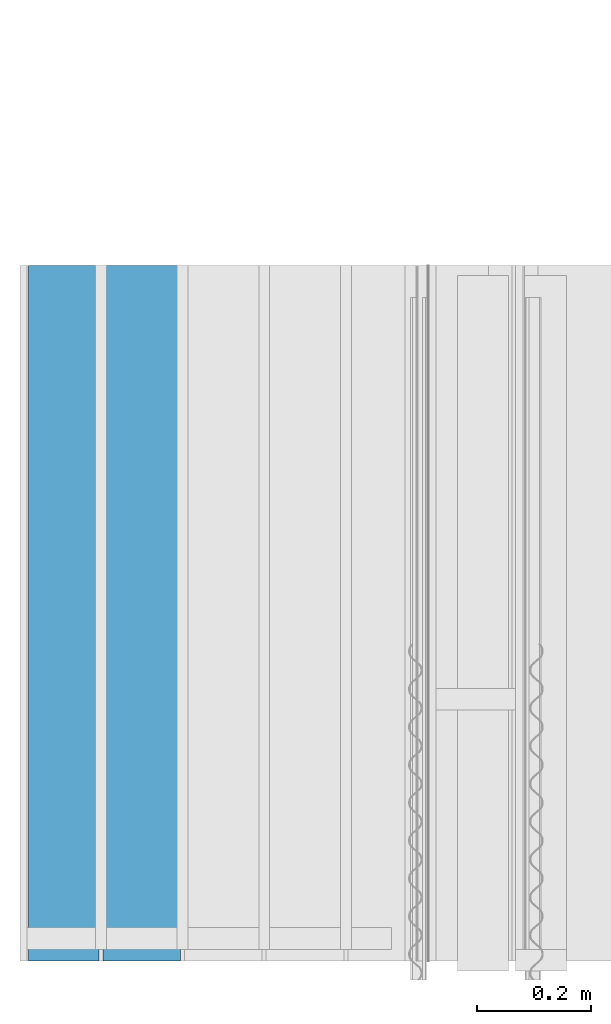
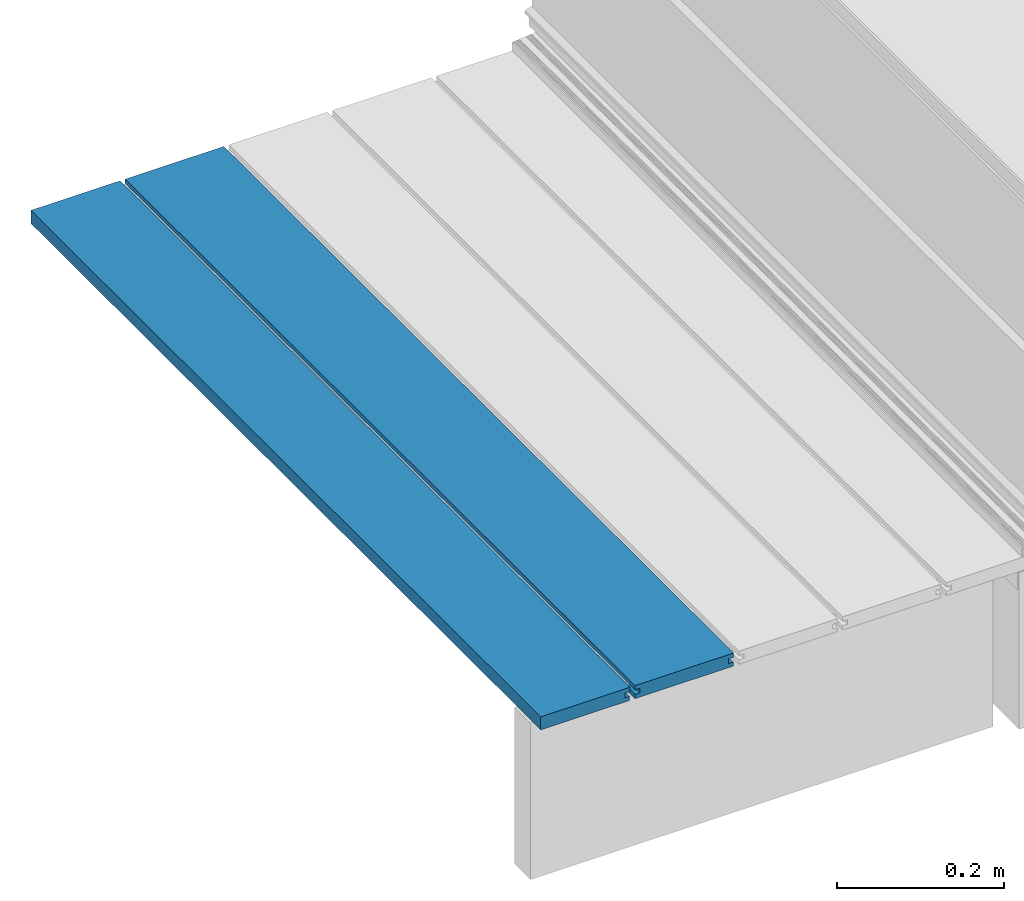
# One storey, part 7 of 33: 2 walls.
"""IFC4 building model written with IfcOpenShell, lengths in feet."""

from ifc_helpers import new_model, entity, si_unit, converted_unit, derived_unit, direction, frame, origin, place, context, subcontext, project, spatial, material, type_object, element, save


model = new_model("IFC4")

# Units and contexts
model_context = context("Model", 3, precision=0.0001, world=origin(), true_north=direction((6.12303176911189e-17, 1.0)))
body_context = subcontext(model_context, "Body", "Model", "MODEL_VIEW")
ifc_project = project(units=[converted_unit("LENGTHUNIT", "FOOT", entity("IfcRatioMeasure", 0.3048), si_unit("LENGTHUNIT", "METRE"), dimensions=[1, 0, 0, 0, 0, 0, 0]), converted_unit("AREAUNIT", "SQUARE FOOT", entity("IfcRatioMeasure", 0.09290304), si_unit("AREAUNIT", "SQUARE_METRE"), dimensions=[2, 0, 0, 0, 0, 0, 0]), converted_unit("VOLUMEUNIT", "CUBIC FOOT", entity("IfcRatioMeasure", 0.028316846592), si_unit("VOLUMEUNIT", "CUBIC_METRE"), dimensions=[3, 0, 0, 0, 0, 0, 0]), converted_unit("PLANEANGLEUNIT", "DEGREE", entity("IfcRatioMeasure", 0.0174532925199433), si_unit("PLANEANGLEUNIT", "RADIAN"), dimensions=[0, 0, 0, 0, 0, 0, 0]), si_unit("MASSUNIT", "GRAM", prefix="KILO"), derived_unit("MASSDENSITYUNIT", [(si_unit("MASSUNIT", "GRAM", prefix="KILO"), 1), (si_unit("LENGTHUNIT", "METRE"), -3)]), derived_unit("MOMENTOFINERTIAUNIT", [(si_unit("LENGTHUNIT", "METRE"), 4)]), si_unit("TIMEUNIT", "SECOND"), si_unit("FREQUENCYUNIT", "HERTZ"), si_unit("THERMODYNAMICTEMPERATUREUNIT", "DEGREE_CELSIUS"), derived_unit("THERMALTRANSMITTANCEUNIT", [(si_unit("MASSUNIT", "GRAM", prefix="KILO"), 1), (si_unit("THERMODYNAMICTEMPERATUREUNIT", "KELVIN"), -1), (si_unit("TIMEUNIT", "SECOND"), -3)]), derived_unit("VOLUMETRICFLOWRATEUNIT", [(si_unit("LENGTHUNIT", "METRE"), 3), (si_unit("TIMEUNIT", "SECOND"), -1)]), si_unit("ELECTRICCURRENTUNIT", "AMPERE"), si_unit("ELECTRICVOLTAGEUNIT", "VOLT"), si_unit("POWERUNIT", "WATT"), si_unit("FORCEUNIT", "NEWTON"), si_unit("ILLUMINANCEUNIT", "LUX"), si_unit("LUMINOUSFLUXUNIT", "LUMEN"), si_unit("LUMINOUSINTENSITYUNIT", "CANDELA"), derived_unit("USERDEFINED", [(si_unit("MASSUNIT", "GRAM", prefix="KILO"), -1), (si_unit("LENGTHUNIT", "METRE"), -2), (si_unit("TIMEUNIT", "SECOND"), 3), (si_unit("LUMINOUSFLUXUNIT", "LUMEN"), 1)]), derived_unit("LINEARVELOCITYUNIT", [(si_unit("LENGTHUNIT", "METRE"), 1), (si_unit("TIMEUNIT", "SECOND"), -1)]), si_unit("PRESSUREUNIT", "PASCAL"), derived_unit("USERDEFINED", [(si_unit("LENGTHUNIT", "METRE"), -2), (si_unit("MASSUNIT", "GRAM", prefix="KILO"), 1), (si_unit("TIMEUNIT", "SECOND"), -2)]), derived_unit("LINEARFORCEUNIT", [(si_unit("MASSUNIT", "GRAM", prefix="KILO"), 1), (si_unit("LENGTHUNIT", "METRE"), 1), (si_unit("TIMEUNIT", "SECOND"), -2), (si_unit("LENGTHUNIT", "METRE"), -1)]), derived_unit("PLANARFORCEUNIT", [(si_unit("MASSUNIT", "GRAM", prefix="KILO"), 1), (si_unit("LENGTHUNIT", "METRE"), 1), (si_unit("TIMEUNIT", "SECOND"), -2), (si_unit("LENGTHUNIT", "METRE"), -2)])], contexts=[model_context])

# Site, building, storey
site_placement = place(None, origin())
site = spatial("IfcSite", under=ifc_project, at=site_placement, CompositionType="ELEMENT")
building_placement = place(site_placement, origin())
building = spatial("IfcBuilding", under=site, at=building_placement, CompositionType="ELEMENT")
storey_placement = place(building_placement, frame((0.0, 0.0, 10.0)))
storey = spatial("IfcBuildingStorey", under=building, at=storey_placement, Name="2ND FLOOR", CompositionType="ELEMENT", Elevation=10.0000000000002)

# Walls
ifc_material = material(Name="COMPOSITE DECKING W/ HIDDEN FASTENERS", Category="Materials")
wall_type_1 = type_object("IfcWallType", Name="Generic Models 648:Generic Models 1", PredefinedType="NOTDEFINED", material=ifc_material)
wall_1_placement = place(storey_placement, frame((1457.39451875699, 2.0, 0.618921366607449), z_axis=(0.0, 0.0, 1.0), x_axis=(0.0, 1.0, 0.0)))
cartesian_point_1 = entity("IfcCartesianPoint", [4.0, 0.0, 0.0])
vertex_point_1 = entity("IfcVertexPoint", cartesian_point_1)
cartesian_point_2 = entity("IfcCartesianPoint", [4.0, 0.0, 0.0198779960861497])
vertex_point_2 = entity("IfcVertexPoint", cartesian_point_2)
ifc_direction_1 = entity("IfcDirection", [0.0, 0.0, 1.0])
edge_curve_1 = entity("IfcEdgeCurve", vertex_point_1, vertex_point_2, entity("IfcTrimmedCurve", entity("IfcLine", cartesian_point_1, entity("IfcVector", ifc_direction_1, 1.0)), [cartesian_point_1], [cartesian_point_2], True, "CARTESIAN"), True)
cartesian_point_3 = entity("IfcCartesianPoint", [4.0, -0.0228400010810219, 0.0198779960861497])
vertex_point_3 = entity("IfcVertexPoint", cartesian_point_3)
ifc_direction_2 = entity("IfcDirection", [0.0, -1.0, 0.0])
edge_curve_2 = entity("IfcEdgeCurve", vertex_point_2, vertex_point_3, entity("IfcTrimmedCurve", entity("IfcLine", cartesian_point_2, entity("IfcVector", ifc_direction_2, 1.0)), [cartesian_point_2], [cartesian_point_3], True, "CARTESIAN"), True)
cartesian_point_4 = entity("IfcCartesianPoint", [4.0, -0.0228400010810219, 0.0422987663426539])
vertex_point_4 = entity("IfcVertexPoint", cartesian_point_4)
edge_curve_3 = entity("IfcEdgeCurve", vertex_point_3, vertex_point_4, entity("IfcTrimmedCurve", entity("IfcLine", cartesian_point_3, entity("IfcVector", ifc_direction_1, 1.0)), [cartesian_point_3], [cartesian_point_4], True, "CARTESIAN"), True)
cartesian_point_5 = entity("IfcCartesianPoint", [4.0, 0.0, 0.0422987663426539])
vertex_point_5 = entity("IfcVertexPoint", cartesian_point_5)
ifc_direction_3 = entity("IfcDirection", [0.0, 1.0, 0.0])
edge_curve_4 = entity("IfcEdgeCurve", vertex_point_4, vertex_point_5, entity("IfcTrimmedCurve", entity("IfcLine", cartesian_point_4, entity("IfcVector", ifc_direction_3, 1.0)), [cartesian_point_4], [cartesian_point_5], True, "CARTESIAN"), True)
cartesian_point_6 = entity("IfcCartesianPoint", [4.0, 0.0, 0.0625000000000018])
vertex_point_6 = entity("IfcVertexPoint", cartesian_point_6)
edge_curve_5 = entity("IfcEdgeCurve", vertex_point_5, vertex_point_6, entity("IfcTrimmedCurve", entity("IfcLine", cartesian_point_5, entity("IfcVector", ifc_direction_1, 1.0)), [cartesian_point_5], [cartesian_point_6], True, "CARTESIAN"), True)
cartesian_point_7 = entity("IfcCartesianPoint", [4.0, -0.446740923891639, 0.0625000000000568])
vertex_point_7 = entity("IfcVertexPoint", cartesian_point_7)
edge_curve_6 = entity("IfcEdgeCurve", vertex_point_6, vertex_point_7, entity("IfcTrimmedCurve", entity("IfcLine", cartesian_point_6, entity("IfcVector", ifc_direction_2, 1.0)), [cartesian_point_6], [cartesian_point_7], True, "CARTESIAN"), True)
cartesian_point_8 = entity("IfcCartesianPoint", [4.0, -0.446740923891639, 0.0422987663426539])
vertex_point_8 = entity("IfcVertexPoint", cartesian_point_8)
ifc_direction_4 = entity("IfcDirection", [0.0, 0.0, -1.0])
edge_curve_7 = entity("IfcEdgeCurve", vertex_point_7, vertex_point_8, entity("IfcTrimmedCurve", entity("IfcLine", cartesian_point_7, entity("IfcVector", ifc_direction_4, 1.0)), [cartesian_point_7], [cartesian_point_8], True, "CARTESIAN"), True)
cartesian_point_9 = entity("IfcCartesianPoint", [4.0, -0.423900922810844, 0.0422987663426539])
vertex_point_9 = entity("IfcVertexPoint", cartesian_point_9)
edge_curve_8 = entity("IfcEdgeCurve", vertex_point_8, vertex_point_9, entity("IfcTrimmedCurve", entity("IfcLine", cartesian_point_8, entity("IfcVector", ifc_direction_3, 1.0)), [cartesian_point_8], [cartesian_point_9], True, "CARTESIAN"), True)
cartesian_point_10 = entity("IfcCartesianPoint", [4.0, -0.423900922810844, 0.0198779960861497])
vertex_point_10 = entity("IfcVertexPoint", cartesian_point_10)
edge_curve_9 = entity("IfcEdgeCurve", vertex_point_9, vertex_point_10, entity("IfcTrimmedCurve", entity("IfcLine", cartesian_point_9, entity("IfcVector", ifc_direction_4, 1.0)), [cartesian_point_9], [cartesian_point_10], True, "CARTESIAN"), True)
cartesian_point_11 = entity("IfcCartesianPoint", [4.0, -0.445416170097133, 0.0198779960861497])
vertex_point_11 = entity("IfcVertexPoint", cartesian_point_11)
edge_curve_10 = entity("IfcEdgeCurve", vertex_point_10, vertex_point_11, entity("IfcTrimmedCurve", entity("IfcLine", cartesian_point_10, entity("IfcVector", ifc_direction_2, 1.0)), [cartesian_point_10], [cartesian_point_11], True, "CARTESIAN"), True)
cartesian_point_12 = entity("IfcCartesianPoint", [4.0, -0.445416170097133, 0.0])
vertex_point_12 = entity("IfcVertexPoint", cartesian_point_12)
edge_curve_11 = entity("IfcEdgeCurve", vertex_point_11, vertex_point_12, entity("IfcTrimmedCurve", entity("IfcLine", cartesian_point_11, entity("IfcVector", ifc_direction_4, 1.0)), [cartesian_point_11], [cartesian_point_12], True, "CARTESIAN"), True)
edge_curve_12 = entity("IfcEdgeCurve", vertex_point_12, vertex_point_1, entity("IfcTrimmedCurve", entity("IfcLine", cartesian_point_12, entity("IfcVector", ifc_direction_3, 1.0)), [cartesian_point_12], [cartesian_point_1], True, "CARTESIAN"), True)
ifc_direction_5 = entity("IfcDirection", [1.0, 0.0, 0.0])
cartesian_point_13 = entity("IfcCartesianPoint", [0.0, 0.0, 0.0])
vertex_point_13 = entity("IfcVertexPoint", cartesian_point_13)
cartesian_point_14 = entity("IfcCartesianPoint", [0.0, -0.445416170097133, 0.0])
vertex_point_14 = entity("IfcVertexPoint", cartesian_point_14)
edge_curve_13 = entity("IfcEdgeCurve", vertex_point_13, vertex_point_14, entity("IfcTrimmedCurve", entity("IfcLine", cartesian_point_13, entity("IfcVector", ifc_direction_2, 1.0)), [cartesian_point_13], [cartesian_point_14], True, "CARTESIAN"), True)
cartesian_point_15 = entity("IfcCartesianPoint", [0.0, -0.445416170097133, 0.0198779960861462])
vertex_point_15 = entity("IfcVertexPoint", cartesian_point_15)
edge_curve_14 = entity("IfcEdgeCurve", vertex_point_14, vertex_point_15, entity("IfcTrimmedCurve", entity("IfcLine", cartesian_point_14, entity("IfcVector", ifc_direction_1, 1.0)), [cartesian_point_14], [cartesian_point_15], True, "CARTESIAN"), True)
cartesian_point_16 = entity("IfcCartesianPoint", [0.0, -0.423900922810844, 0.0198779960861462])
vertex_point_16 = entity("IfcVertexPoint", cartesian_point_16)
edge_curve_15 = entity("IfcEdgeCurve", vertex_point_15, vertex_point_16, entity("IfcTrimmedCurve", entity("IfcLine", cartesian_point_15, entity("IfcVector", ifc_direction_3, 1.0)), [cartesian_point_15], [cartesian_point_16], True, "CARTESIAN"), True)
cartesian_point_17 = entity("IfcCartesianPoint", [0.0, -0.423900922810844, 0.0422987663426522])
vertex_point_17 = entity("IfcVertexPoint", cartesian_point_17)
edge_curve_16 = entity("IfcEdgeCurve", vertex_point_16, vertex_point_17, entity("IfcTrimmedCurve", entity("IfcLine", cartesian_point_16, entity("IfcVector", ifc_direction_1, 1.0)), [cartesian_point_16], [cartesian_point_17], True, "CARTESIAN"), True)
cartesian_point_18 = entity("IfcCartesianPoint", [0.0, -0.446740923891639, 0.0422987663426522])
vertex_point_18 = entity("IfcVertexPoint", cartesian_point_18)
edge_curve_17 = entity("IfcEdgeCurve", vertex_point_17, vertex_point_18, entity("IfcTrimmedCurve", entity("IfcLine", cartesian_point_17, entity("IfcVector", ifc_direction_2, 1.0)), [cartesian_point_17], [cartesian_point_18], True, "CARTESIAN"), True)
cartesian_point_19 = entity("IfcCartesianPoint", [0.0, -0.446740923891639, 0.0625000000000551])
vertex_point_19 = entity("IfcVertexPoint", cartesian_point_19)
edge_curve_18 = entity("IfcEdgeCurve", vertex_point_18, vertex_point_19, entity("IfcTrimmedCurve", entity("IfcLine", cartesian_point_18, entity("IfcVector", ifc_direction_1, 1.0)), [cartesian_point_18], [cartesian_point_19], True, "CARTESIAN"), True)
cartesian_point_20 = entity("IfcCartesianPoint", [0.0, 0.0, 0.0624999999999982])
vertex_point_20 = entity("IfcVertexPoint", cartesian_point_20)
edge_curve_19 = entity("IfcEdgeCurve", vertex_point_19, vertex_point_20, entity("IfcTrimmedCurve", entity("IfcLine", cartesian_point_19, entity("IfcVector", ifc_direction_3, 1.0)), [cartesian_point_19], [cartesian_point_20], True, "CARTESIAN"), True)
cartesian_point_21 = entity("IfcCartesianPoint", [0.0, 0.0, 0.0422987663426522])
vertex_point_21 = entity("IfcVertexPoint", cartesian_point_21)
edge_curve_20 = entity("IfcEdgeCurve", vertex_point_20, vertex_point_21, entity("IfcTrimmedCurve", entity("IfcLine", cartesian_point_20, entity("IfcVector", ifc_direction_4, 1.0)), [cartesian_point_20], [cartesian_point_21], True, "CARTESIAN"), True)
cartesian_point_22 = entity("IfcCartesianPoint", [0.0, -0.0228400010810219, 0.0422987663426522])
vertex_point_22 = entity("IfcVertexPoint", cartesian_point_22)
edge_curve_21 = entity("IfcEdgeCurve", vertex_point_21, vertex_point_22, entity("IfcTrimmedCurve", entity("IfcLine", cartesian_point_21, entity("IfcVector", ifc_direction_2, 1.0)), [cartesian_point_21], [cartesian_point_22], True, "CARTESIAN"), True)
cartesian_point_23 = entity("IfcCartesianPoint", [0.0, -0.0228400010810219, 0.0198779960861462])
vertex_point_23 = entity("IfcVertexPoint", cartesian_point_23)
edge_curve_22 = entity("IfcEdgeCurve", vertex_point_22, vertex_point_23, entity("IfcTrimmedCurve", entity("IfcLine", cartesian_point_22, entity("IfcVector", ifc_direction_4, 1.0)), [cartesian_point_22], [cartesian_point_23], True, "CARTESIAN"), True)
cartesian_point_24 = entity("IfcCartesianPoint", [0.0, 0.0, 0.0198779960861462])
vertex_point_24 = entity("IfcVertexPoint", cartesian_point_24)
edge_curve_23 = entity("IfcEdgeCurve", vertex_point_23, vertex_point_24, entity("IfcTrimmedCurve", entity("IfcLine", cartesian_point_23, entity("IfcVector", ifc_direction_3, 1.0)), [cartesian_point_23], [cartesian_point_24], True, "CARTESIAN"), True)
edge_curve_24 = entity("IfcEdgeCurve", vertex_point_24, vertex_point_13, entity("IfcTrimmedCurve", entity("IfcLine", cartesian_point_24, entity("IfcVector", ifc_direction_4, 1.0)), [cartesian_point_24], [cartesian_point_13], True, "CARTESIAN"), True)
ifc_direction_6 = entity("IfcDirection", [-1.0, 0.0, 0.0])
edge_curve_25 = entity("IfcEdgeCurve", vertex_point_24, vertex_point_2, entity("IfcTrimmedCurve", entity("IfcLine", cartesian_point_24, entity("IfcVector", ifc_direction_5, 1.0)), [cartesian_point_24], [cartesian_point_2], True, "CARTESIAN"), True)
edge_curve_26 = entity("IfcEdgeCurve", vertex_point_1, vertex_point_13, entity("IfcTrimmedCurve", entity("IfcLine", cartesian_point_13, entity("IfcVector", ifc_direction_6, 1.0)), [cartesian_point_1], [cartesian_point_13], True, "CARTESIAN"), True)
edge_curve_27 = entity("IfcEdgeCurve", vertex_point_19, vertex_point_7, entity("IfcTrimmedCurve", entity("IfcLine", cartesian_point_19, entity("IfcVector", ifc_direction_5, 1.0)), [cartesian_point_19], [cartesian_point_7], True, "CARTESIAN"), True)
edge_curve_28 = entity("IfcEdgeCurve", vertex_point_6, vertex_point_20, entity("IfcTrimmedCurve", entity("IfcLine", cartesian_point_20, entity("IfcVector", ifc_direction_6, 1.0)), [cartesian_point_6], [cartesian_point_20], True, "CARTESIAN"), True)
edge_curve_29 = entity("IfcEdgeCurve", vertex_point_18, vertex_point_8, entity("IfcTrimmedCurve", entity("IfcLine", cartesian_point_18, entity("IfcVector", ifc_direction_5, 1.0)), [cartesian_point_18], [cartesian_point_8], True, "CARTESIAN"), True)
edge_curve_30 = entity("IfcEdgeCurve", vertex_point_12, vertex_point_14, entity("IfcTrimmedCurve", entity("IfcLine", cartesian_point_14, entity("IfcVector", ifc_direction_6, 1.0)), [cartesian_point_12], [cartesian_point_14], True, "CARTESIAN"), True)
edge_curve_31 = entity("IfcEdgeCurve", vertex_point_5, vertex_point_21, entity("IfcTrimmedCurve", entity("IfcLine", cartesian_point_21, entity("IfcVector", ifc_direction_6, 1.0)), [cartesian_point_5], [cartesian_point_21], True, "CARTESIAN"), True)
edge_curve_32 = entity("IfcEdgeCurve", vertex_point_17, vertex_point_9, entity("IfcTrimmedCurve", entity("IfcLine", cartesian_point_17, entity("IfcVector", ifc_direction_5, 1.0)), [cartesian_point_17], [cartesian_point_9], True, "CARTESIAN"), True)
edge_curve_33 = entity("IfcEdgeCurve", vertex_point_16, vertex_point_10, entity("IfcTrimmedCurve", entity("IfcLine", cartesian_point_16, entity("IfcVector", ifc_direction_5, 1.0)), [cartesian_point_16], [cartesian_point_10], True, "CARTESIAN"), True)
edge_curve_34 = entity("IfcEdgeCurve", vertex_point_15, vertex_point_11, entity("IfcTrimmedCurve", entity("IfcLine", cartesian_point_15, entity("IfcVector", ifc_direction_5, 1.0)), [cartesian_point_15], [cartesian_point_11], True, "CARTESIAN"), True)
edge_curve_35 = entity("IfcEdgeCurve", vertex_point_23, vertex_point_3, entity("IfcTrimmedCurve", entity("IfcLine", cartesian_point_23, entity("IfcVector", ifc_direction_5, 1.0)), [cartesian_point_23], [cartesian_point_3], True, "CARTESIAN"), True)
edge_curve_36 = entity("IfcEdgeCurve", vertex_point_22, vertex_point_4, entity("IfcTrimmedCurve", entity("IfcLine", cartesian_point_22, entity("IfcVector", ifc_direction_5, 1.0)), [cartesian_point_22], [cartesian_point_4], True, "CARTESIAN"), True)
element("IfcWall", 1, at=wall_1_placement, inside=storey, type_object=wall_type_1, material=ifc_material, Name="Generic Models 648:Generic Models 1", ObjectType="Generic Models 648:Generic Models 1", PredefinedType="NOTDEFINED", context=body_context, shape_type="AdvancedBrep", body=[
    entity("IfcAdvancedBrep", entity("IfcClosedShell", [entity("IfcAdvancedFace", [entity("IfcFaceOuterBound", entity("IfcEdgeLoop", [entity("IfcOrientedEdge", None, None, edge_curve_1, True), entity("IfcOrientedEdge", None, None, edge_curve_2, True), entity("IfcOrientedEdge", None, None, edge_curve_3, True), entity("IfcOrientedEdge", None, None, edge_curve_4, True), entity("IfcOrientedEdge", None, None, edge_curve_5, True), entity("IfcOrientedEdge", None, None, edge_curve_6, True), entity("IfcOrientedEdge", None, None, edge_curve_7, True), entity("IfcOrientedEdge", None, None, edge_curve_8, True), entity("IfcOrientedEdge", None, None, edge_curve_9, True), entity("IfcOrientedEdge", None, None, edge_curve_10, True), entity("IfcOrientedEdge", None, None, edge_curve_11, True), entity("IfcOrientedEdge", None, None, edge_curve_12, True)]), True)], entity("IfcPlane", entity("IfcAxis2Placement3D", entity("IfcCartesianPoint", [4.0, 3.98642313864389, 0.0]), ifc_direction_5, ifc_direction_3)), True), entity("IfcAdvancedFace", [entity("IfcFaceOuterBound", entity("IfcEdgeLoop", [entity("IfcOrientedEdge", None, None, edge_curve_13, True), entity("IfcOrientedEdge", None, None, edge_curve_14, True), entity("IfcOrientedEdge", None, None, edge_curve_15, True), entity("IfcOrientedEdge", None, None, edge_curve_16, True), entity("IfcOrientedEdge", None, None, edge_curve_17, True), entity("IfcOrientedEdge", None, None, edge_curve_18, True), entity("IfcOrientedEdge", None, None, edge_curve_19, True), entity("IfcOrientedEdge", None, None, edge_curve_20, True), entity("IfcOrientedEdge", None, None, edge_curve_21, True), entity("IfcOrientedEdge", None, None, edge_curve_22, True), entity("IfcOrientedEdge", None, None, edge_curve_23, True), entity("IfcOrientedEdge", None, None, edge_curve_24, True)]), True)], entity("IfcPlane", entity("IfcAxis2Placement3D", entity("IfcCartesianPoint", [0.0, 3.98642313864389, 0.0]), ifc_direction_6, ifc_direction_2)), True), entity("IfcAdvancedFace", [entity("IfcFaceOuterBound", entity("IfcEdgeLoop", [entity("IfcOrientedEdge", None, None, edge_curve_24, False), entity("IfcOrientedEdge", None, None, edge_curve_25, True), entity("IfcOrientedEdge", None, None, edge_curve_1, False), entity("IfcOrientedEdge", None, None, edge_curve_26, True)]), True)], entity("IfcPlane", entity("IfcAxis2Placement3D", cartesian_point_24, ifc_direction_3, ifc_direction_5)), True), entity("IfcAdvancedFace", [entity("IfcFaceOuterBound", entity("IfcEdgeLoop", [entity("IfcOrientedEdge", None, None, edge_curve_19, False), entity("IfcOrientedEdge", None, None, edge_curve_27, True), entity("IfcOrientedEdge", None, None, edge_curve_6, False), entity("IfcOrientedEdge", None, None, edge_curve_28, True)]), True)], entity("IfcPlane", entity("IfcAxis2Placement3D", cartesian_point_19, ifc_direction_1, ifc_direction_5)), True), entity("IfcAdvancedFace", [entity("IfcFaceOuterBound", entity("IfcEdgeLoop", [entity("IfcOrientedEdge", None, None, edge_curve_18, False), entity("IfcOrientedEdge", None, None, edge_curve_29, True), entity("IfcOrientedEdge", None, None, edge_curve_7, False), entity("IfcOrientedEdge", None, None, edge_curve_27, False)]), True)], entity("IfcPlane", entity("IfcAxis2Placement3D", cartesian_point_18, ifc_direction_2, ifc_direction_5)), True), entity("IfcAdvancedFace", [entity("IfcFaceOuterBound", entity("IfcEdgeLoop", [entity("IfcOrientedEdge", None, None, edge_curve_13, False), entity("IfcOrientedEdge", None, None, edge_curve_26, False), entity("IfcOrientedEdge", None, None, edge_curve_12, False), entity("IfcOrientedEdge", None, None, edge_curve_30, True)]), True)], entity("IfcPlane", entity("IfcAxis2Placement3D", cartesian_point_13, ifc_direction_4, ifc_direction_5)), True), entity("IfcAdvancedFace", [entity("IfcFaceOuterBound", entity("IfcEdgeLoop", [entity("IfcOrientedEdge", None, None, edge_curve_20, False), entity("IfcOrientedEdge", None, None, edge_curve_28, False), entity("IfcOrientedEdge", None, None, edge_curve_5, False), entity("IfcOrientedEdge", None, None, edge_curve_31, True)]), True)], entity("IfcPlane", entity("IfcAxis2Placement3D", cartesian_point_20, ifc_direction_3, ifc_direction_5)), True), entity("IfcAdvancedFace", [entity("IfcFaceOuterBound", entity("IfcEdgeLoop", [entity("IfcOrientedEdge", None, None, edge_curve_17, False), entity("IfcOrientedEdge", None, None, edge_curve_32, True), entity("IfcOrientedEdge", None, None, edge_curve_8, False), entity("IfcOrientedEdge", None, None, edge_curve_29, False)]), True)], entity("IfcPlane", entity("IfcAxis2Placement3D", cartesian_point_17, ifc_direction_4, ifc_direction_5)), True), entity("IfcAdvancedFace", [entity("IfcFaceOuterBound", entity("IfcEdgeLoop", [entity("IfcOrientedEdge", None, None, edge_curve_16, False), entity("IfcOrientedEdge", None, None, edge_curve_33, True), entity("IfcOrientedEdge", None, None, edge_curve_9, False), entity("IfcOrientedEdge", None, None, edge_curve_32, False)]), True)], entity("IfcPlane", entity("IfcAxis2Placement3D", cartesian_point_16, ifc_direction_2, ifc_direction_5)), True), entity("IfcAdvancedFace", [entity("IfcFaceOuterBound", entity("IfcEdgeLoop", [entity("IfcOrientedEdge", None, None, edge_curve_15, False), entity("IfcOrientedEdge", None, None, edge_curve_34, True), entity("IfcOrientedEdge", None, None, edge_curve_10, False), entity("IfcOrientedEdge", None, None, edge_curve_33, False)]), True)], entity("IfcPlane", entity("IfcAxis2Placement3D", cartesian_point_15, ifc_direction_1, ifc_direction_5)), True), entity("IfcAdvancedFace", [entity("IfcFaceOuterBound", entity("IfcEdgeLoop", [entity("IfcOrientedEdge", None, None, edge_curve_14, False), entity("IfcOrientedEdge", None, None, edge_curve_30, False), entity("IfcOrientedEdge", None, None, edge_curve_11, False), entity("IfcOrientedEdge", None, None, edge_curve_34, False)]), True)], entity("IfcPlane", entity("IfcAxis2Placement3D", cartesian_point_14, ifc_direction_2, ifc_direction_5)), True), entity("IfcAdvancedFace", [entity("IfcFaceOuterBound", entity("IfcEdgeLoop", [entity("IfcOrientedEdge", None, None, edge_curve_23, False), entity("IfcOrientedEdge", None, None, edge_curve_35, True), entity("IfcOrientedEdge", None, None, edge_curve_2, False), entity("IfcOrientedEdge", None, None, edge_curve_25, False)]), True)], entity("IfcPlane", entity("IfcAxis2Placement3D", cartesian_point_23, ifc_direction_1, ifc_direction_5)), True), entity("IfcAdvancedFace", [entity("IfcFaceOuterBound", entity("IfcEdgeLoop", [entity("IfcOrientedEdge", None, None, edge_curve_22, False), entity("IfcOrientedEdge", None, None, edge_curve_36, True), entity("IfcOrientedEdge", None, None, edge_curve_3, False), entity("IfcOrientedEdge", None, None, edge_curve_35, False)]), True)], entity("IfcPlane", entity("IfcAxis2Placement3D", cartesian_point_22, ifc_direction_3, ifc_direction_5)), True), entity("IfcAdvancedFace", [entity("IfcFaceOuterBound", entity("IfcEdgeLoop", [entity("IfcOrientedEdge", None, None, edge_curve_21, False), entity("IfcOrientedEdge", None, None, edge_curve_31, False), entity("IfcOrientedEdge", None, None, edge_curve_4, False), entity("IfcOrientedEdge", None, None, edge_curve_36, False)]), True)], entity("IfcPlane", entity("IfcAxis2Placement3D", cartesian_point_21, ifc_direction_4, ifc_direction_5)), True)])),
])
wall_type_2 = type_object("IfcWallType", Name="Generic Models 654:Generic Models 1", PredefinedType="NOTDEFINED", material=ifc_material)
wall_2_placement = place(storey_placement, frame((1456.96702563749, 2.0, 0.61892136660745), z_axis=(0.0, 0.0, 1.0), x_axis=(0.0, 1.0, 0.0)))
cartesian_point_25 = entity("IfcCartesianPoint", [4.0, 0.0, 0.0])
vertex_point_25 = entity("IfcVertexPoint", cartesian_point_25)
cartesian_point_26 = entity("IfcCartesianPoint", [4.0, 0.0, 0.0625])
vertex_point_26 = entity("IfcVertexPoint", cartesian_point_26)
ifc_direction_7 = entity("IfcDirection", [0.0, 0.0, 1.0])
edge_curve_37 = entity("IfcEdgeCurve", vertex_point_25, vertex_point_26, entity("IfcTrimmedCurve", entity("IfcLine", cartesian_point_25, entity("IfcVector", ifc_direction_7, 1.0)), [cartesian_point_25], [cartesian_point_26], True, "CARTESIAN"), True)
cartesian_point_27 = entity("IfcCartesianPoint", [4.0, -0.404467741293047, 0.0625000000000515])
vertex_point_27 = entity("IfcVertexPoint", cartesian_point_27)
ifc_direction_8 = entity("IfcDirection", [0.0, -1.0, 0.0])
edge_curve_38 = entity("IfcEdgeCurve", vertex_point_26, vertex_point_27, entity("IfcTrimmedCurve", entity("IfcLine", cartesian_point_26, entity("IfcVector", ifc_direction_8, 1.0)), [cartesian_point_26], [cartesian_point_27], True, "CARTESIAN"), True)
cartesian_point_28 = entity("IfcCartesianPoint", [4.0, -0.404467741293047, 0.0422987663426486])
vertex_point_28 = entity("IfcVertexPoint", cartesian_point_28)
ifc_direction_9 = entity("IfcDirection", [0.0, 0.0, -1.0])
edge_curve_39 = entity("IfcEdgeCurve", vertex_point_27, vertex_point_28, entity("IfcTrimmedCurve", entity("IfcLine", cartesian_point_27, entity("IfcVector", ifc_direction_9, 1.0)), [cartesian_point_27], [cartesian_point_28], True, "CARTESIAN"), True)
cartesian_point_29 = entity("IfcCartesianPoint", [4.0, -0.381627740212252, 0.0422987663426486])
vertex_point_29 = entity("IfcVertexPoint", cartesian_point_29)
ifc_direction_10 = entity("IfcDirection", [0.0, 1.0, 0.0])
edge_curve_40 = entity("IfcEdgeCurve", vertex_point_28, vertex_point_29, entity("IfcTrimmedCurve", entity("IfcLine", cartesian_point_28, entity("IfcVector", ifc_direction_10, 1.0)), [cartesian_point_28], [cartesian_point_29], True, "CARTESIAN"), True)
cartesian_point_30 = entity("IfcCartesianPoint", [4.0, -0.381627740212252, 0.0198779960861444])
vertex_point_30 = entity("IfcVertexPoint", cartesian_point_30)
edge_curve_41 = entity("IfcEdgeCurve", vertex_point_29, vertex_point_30, entity("IfcTrimmedCurve", entity("IfcLine", cartesian_point_29, entity("IfcVector", ifc_direction_9, 1.0)), [cartesian_point_29], [cartesian_point_30], True, "CARTESIAN"), True)
cartesian_point_31 = entity("IfcCartesianPoint", [4.0, -0.403142987498541, 0.0198779960861444])
vertex_point_31 = entity("IfcVertexPoint", cartesian_point_31)
edge_curve_42 = entity("IfcEdgeCurve", vertex_point_30, vertex_point_31, entity("IfcTrimmedCurve", entity("IfcLine", cartesian_point_30, entity("IfcVector", ifc_direction_8, 1.0)), [cartesian_point_30], [cartesian_point_31], True, "CARTESIAN"), True)
cartesian_point_32 = entity("IfcCartesianPoint", [4.0, -0.403142987498541, 0.0])
vertex_point_32 = entity("IfcVertexPoint", cartesian_point_32)
edge_curve_43 = entity("IfcEdgeCurve", vertex_point_31, vertex_point_32, entity("IfcTrimmedCurve", entity("IfcLine", cartesian_point_31, entity("IfcVector", ifc_direction_9, 1.0)), [cartesian_point_31], [cartesian_point_32], True, "CARTESIAN"), True)
edge_curve_44 = entity("IfcEdgeCurve", vertex_point_32, vertex_point_25, entity("IfcTrimmedCurve", entity("IfcLine", cartesian_point_32, entity("IfcVector", ifc_direction_10, 1.0)), [cartesian_point_32], [cartesian_point_25], True, "CARTESIAN"), True)
ifc_direction_11 = entity("IfcDirection", [1.0, 0.0, 0.0])
cartesian_point_33 = entity("IfcCartesianPoint", [0.0, 0.0, 0.0])
vertex_point_33 = entity("IfcVertexPoint", cartesian_point_33)
cartesian_point_34 = entity("IfcCartesianPoint", [0.0, -0.403142987498541, 0.0])
vertex_point_34 = entity("IfcVertexPoint", cartesian_point_34)
edge_curve_45 = entity("IfcEdgeCurve", vertex_point_33, vertex_point_34, entity("IfcTrimmedCurve", entity("IfcLine", cartesian_point_33, entity("IfcVector", ifc_direction_8, 1.0)), [cartesian_point_33], [cartesian_point_34], True, "CARTESIAN"), True)
cartesian_point_35 = entity("IfcCartesianPoint", [0.0, -0.403142987498541, 0.0198779960861444])
vertex_point_35 = entity("IfcVertexPoint", cartesian_point_35)
edge_curve_46 = entity("IfcEdgeCurve", vertex_point_34, vertex_point_35, entity("IfcTrimmedCurve", entity("IfcLine", cartesian_point_34, entity("IfcVector", ifc_direction_7, 1.0)), [cartesian_point_34], [cartesian_point_35], True, "CARTESIAN"), True)
cartesian_point_36 = entity("IfcCartesianPoint", [0.0, -0.381627740212252, 0.0198779960861444])
vertex_point_36 = entity("IfcVertexPoint", cartesian_point_36)
edge_curve_47 = entity("IfcEdgeCurve", vertex_point_35, vertex_point_36, entity("IfcTrimmedCurve", entity("IfcLine", cartesian_point_35, entity("IfcVector", ifc_direction_10, 1.0)), [cartesian_point_35], [cartesian_point_36], True, "CARTESIAN"), True)
cartesian_point_37 = entity("IfcCartesianPoint", [0.0, -0.381627740212252, 0.0422987663426486])
vertex_point_37 = entity("IfcVertexPoint", cartesian_point_37)
edge_curve_48 = entity("IfcEdgeCurve", vertex_point_36, vertex_point_37, entity("IfcTrimmedCurve", entity("IfcLine", cartesian_point_36, entity("IfcVector", ifc_direction_7, 1.0)), [cartesian_point_36], [cartesian_point_37], True, "CARTESIAN"), True)
cartesian_point_38 = entity("IfcCartesianPoint", [0.0, -0.404467741293047, 0.0422987663426486])
vertex_point_38 = entity("IfcVertexPoint", cartesian_point_38)
edge_curve_49 = entity("IfcEdgeCurve", vertex_point_37, vertex_point_38, entity("IfcTrimmedCurve", entity("IfcLine", cartesian_point_37, entity("IfcVector", ifc_direction_8, 1.0)), [cartesian_point_37], [cartesian_point_38], True, "CARTESIAN"), True)
cartesian_point_39 = entity("IfcCartesianPoint", [0.0, -0.404467741293047, 0.0625000000000515])
vertex_point_39 = entity("IfcVertexPoint", cartesian_point_39)
edge_curve_50 = entity("IfcEdgeCurve", vertex_point_38, vertex_point_39, entity("IfcTrimmedCurve", entity("IfcLine", cartesian_point_38, entity("IfcVector", ifc_direction_7, 1.0)), [cartesian_point_38], [cartesian_point_39], True, "CARTESIAN"), True)
cartesian_point_40 = entity("IfcCartesianPoint", [0.0, 0.0, 0.0625])
vertex_point_40 = entity("IfcVertexPoint", cartesian_point_40)
edge_curve_51 = entity("IfcEdgeCurve", vertex_point_39, vertex_point_40, entity("IfcTrimmedCurve", entity("IfcLine", cartesian_point_39, entity("IfcVector", ifc_direction_10, 1.0)), [cartesian_point_39], [cartesian_point_40], True, "CARTESIAN"), True)
edge_curve_52 = entity("IfcEdgeCurve", vertex_point_40, vertex_point_33, entity("IfcTrimmedCurve", entity("IfcLine", cartesian_point_40, entity("IfcVector", ifc_direction_9, 1.0)), [cartesian_point_40], [cartesian_point_33], True, "CARTESIAN"), True)
ifc_direction_12 = entity("IfcDirection", [-1.0, 0.0, 0.0])
edge_curve_53 = entity("IfcEdgeCurve", vertex_point_39, vertex_point_27, entity("IfcTrimmedCurve", entity("IfcLine", cartesian_point_39, entity("IfcVector", ifc_direction_11, 1.0)), [cartesian_point_39], [cartesian_point_27], True, "CARTESIAN"), True)
edge_curve_54 = entity("IfcEdgeCurve", vertex_point_26, vertex_point_40, entity("IfcTrimmedCurve", entity("IfcLine", cartesian_point_40, entity("IfcVector", ifc_direction_12, 1.0)), [cartesian_point_26], [cartesian_point_40], True, "CARTESIAN"), True)
edge_curve_55 = entity("IfcEdgeCurve", vertex_point_38, vertex_point_28, entity("IfcTrimmedCurve", entity("IfcLine", cartesian_point_38, entity("IfcVector", ifc_direction_11, 1.0)), [cartesian_point_38], [cartesian_point_28], True, "CARTESIAN"), True)
edge_curve_56 = entity("IfcEdgeCurve", vertex_point_33, vertex_point_25, entity("IfcTrimmedCurve", entity("IfcLine", cartesian_point_33, entity("IfcVector", ifc_direction_11, 1.0)), [cartesian_point_33], [cartesian_point_25], True, "CARTESIAN"), True)
edge_curve_57 = entity("IfcEdgeCurve", vertex_point_32, vertex_point_34, entity("IfcTrimmedCurve", entity("IfcLine", cartesian_point_34, entity("IfcVector", ifc_direction_12, 1.0)), [cartesian_point_32], [cartesian_point_34], True, "CARTESIAN"), True)
edge_curve_58 = entity("IfcEdgeCurve", vertex_point_37, vertex_point_29, entity("IfcTrimmedCurve", entity("IfcLine", cartesian_point_37, entity("IfcVector", ifc_direction_11, 1.0)), [cartesian_point_37], [cartesian_point_29], True, "CARTESIAN"), True)
edge_curve_59 = entity("IfcEdgeCurve", vertex_point_36, vertex_point_30, entity("IfcTrimmedCurve", entity("IfcLine", cartesian_point_36, entity("IfcVector", ifc_direction_11, 1.0)), [cartesian_point_36], [cartesian_point_30], True, "CARTESIAN"), True)
edge_curve_60 = entity("IfcEdgeCurve", vertex_point_35, vertex_point_31, entity("IfcTrimmedCurve", entity("IfcLine", cartesian_point_35, entity("IfcVector", ifc_direction_11, 1.0)), [cartesian_point_35], [cartesian_point_31], True, "CARTESIAN"), True)
element("IfcWall", 2, at=wall_2_placement, inside=storey, type_object=wall_type_2, material=ifc_material, Name="Generic Models 654:Generic Models 1", ObjectType="Generic Models 654:Generic Models 1", PredefinedType="NOTDEFINED", context=body_context, shape_type="AdvancedBrep", body=[
    entity("IfcAdvancedBrep", entity("IfcClosedShell", [entity("IfcAdvancedFace", [entity("IfcFaceOuterBound", entity("IfcEdgeLoop", [entity("IfcOrientedEdge", None, None, edge_curve_37, True), entity("IfcOrientedEdge", None, None, edge_curve_38, True), entity("IfcOrientedEdge", None, None, edge_curve_39, True), entity("IfcOrientedEdge", None, None, edge_curve_40, True), entity("IfcOrientedEdge", None, None, edge_curve_41, True), entity("IfcOrientedEdge", None, None, edge_curve_42, True), entity("IfcOrientedEdge", None, None, edge_curve_43, True), entity("IfcOrientedEdge", None, None, edge_curve_44, True)]), True)], entity("IfcPlane", entity("IfcAxis2Placement3D", entity("IfcCartesianPoint", [4.0, 4.02869632124248, 0.0]), ifc_direction_11, ifc_direction_10)), True), entity("IfcAdvancedFace", [entity("IfcFaceOuterBound", entity("IfcEdgeLoop", [entity("IfcOrientedEdge", None, None, edge_curve_45, True), entity("IfcOrientedEdge", None, None, edge_curve_46, True), entity("IfcOrientedEdge", None, None, edge_curve_47, True), entity("IfcOrientedEdge", None, None, edge_curve_48, True), entity("IfcOrientedEdge", None, None, edge_curve_49, True), entity("IfcOrientedEdge", None, None, edge_curve_50, True), entity("IfcOrientedEdge", None, None, edge_curve_51, True), entity("IfcOrientedEdge", None, None, edge_curve_52, True)]), True)], entity("IfcPlane", entity("IfcAxis2Placement3D", entity("IfcCartesianPoint", [0.0, 4.02869632124248, 0.0]), ifc_direction_12, ifc_direction_8)), True), entity("IfcAdvancedFace", [entity("IfcFaceOuterBound", entity("IfcEdgeLoop", [entity("IfcOrientedEdge", None, None, edge_curve_51, False), entity("IfcOrientedEdge", None, None, edge_curve_53, True), entity("IfcOrientedEdge", None, None, edge_curve_38, False), entity("IfcOrientedEdge", None, None, edge_curve_54, True)]), True)], entity("IfcPlane", entity("IfcAxis2Placement3D", cartesian_point_39, ifc_direction_7, ifc_direction_11)), True), entity("IfcAdvancedFace", [entity("IfcFaceOuterBound", entity("IfcEdgeLoop", [entity("IfcOrientedEdge", None, None, edge_curve_50, False), entity("IfcOrientedEdge", None, None, edge_curve_55, True), entity("IfcOrientedEdge", None, None, edge_curve_39, False), entity("IfcOrientedEdge", None, None, edge_curve_53, False)]), True)], entity("IfcPlane", entity("IfcAxis2Placement3D", cartesian_point_38, ifc_direction_8, ifc_direction_11)), True), entity("IfcAdvancedFace", [entity("IfcFaceOuterBound", entity("IfcEdgeLoop", [entity("IfcOrientedEdge", None, None, edge_curve_45, False), entity("IfcOrientedEdge", None, None, edge_curve_56, True), entity("IfcOrientedEdge", None, None, edge_curve_44, False), entity("IfcOrientedEdge", None, None, edge_curve_57, True)]), True)], entity("IfcPlane", entity("IfcAxis2Placement3D", cartesian_point_33, ifc_direction_9, ifc_direction_11)), True), entity("IfcAdvancedFace", [entity("IfcFaceOuterBound", entity("IfcEdgeLoop", [entity("IfcOrientedEdge", None, None, edge_curve_49, False), entity("IfcOrientedEdge", None, None, edge_curve_58, True), entity("IfcOrientedEdge", None, None, edge_curve_40, False), entity("IfcOrientedEdge", None, None, edge_curve_55, False)]), True)], entity("IfcPlane", entity("IfcAxis2Placement3D", cartesian_point_37, ifc_direction_9, ifc_direction_11)), True), entity("IfcAdvancedFace", [entity("IfcFaceOuterBound", entity("IfcEdgeLoop", [entity("IfcOrientedEdge", None, None, edge_curve_48, False), entity("IfcOrientedEdge", None, None, edge_curve_59, True), entity("IfcOrientedEdge", None, None, edge_curve_41, False), entity("IfcOrientedEdge", None, None, edge_curve_58, False)]), True)], entity("IfcPlane", entity("IfcAxis2Placement3D", cartesian_point_36, ifc_direction_8, ifc_direction_11)), True), entity("IfcAdvancedFace", [entity("IfcFaceOuterBound", entity("IfcEdgeLoop", [entity("IfcOrientedEdge", None, None, edge_curve_47, False), entity("IfcOrientedEdge", None, None, edge_curve_60, True), entity("IfcOrientedEdge", None, None, edge_curve_42, False), entity("IfcOrientedEdge", None, None, edge_curve_59, False)]), True)], entity("IfcPlane", entity("IfcAxis2Placement3D", cartesian_point_35, ifc_direction_7, ifc_direction_11)), True), entity("IfcAdvancedFace", [entity("IfcFaceOuterBound", entity("IfcEdgeLoop", [entity("IfcOrientedEdge", None, None, edge_curve_46, False), entity("IfcOrientedEdge", None, None, edge_curve_57, False), entity("IfcOrientedEdge", None, None, edge_curve_43, False), entity("IfcOrientedEdge", None, None, edge_curve_60, False)]), True)], entity("IfcPlane", entity("IfcAxis2Placement3D", cartesian_point_34, ifc_direction_8, ifc_direction_11)), True), entity("IfcAdvancedFace", [entity("IfcFaceOuterBound", entity("IfcEdgeLoop", [entity("IfcOrientedEdge", None, None, edge_curve_52, False), entity("IfcOrientedEdge", None, None, edge_curve_54, False), entity("IfcOrientedEdge", None, None, edge_curve_37, False), entity("IfcOrientedEdge", None, None, edge_curve_56, False)]), True)], entity("IfcPlane", entity("IfcAxis2Placement3D", cartesian_point_40, ifc_direction_10, ifc_direction_11)), True)])),
])

save(model, "model.ifc")
